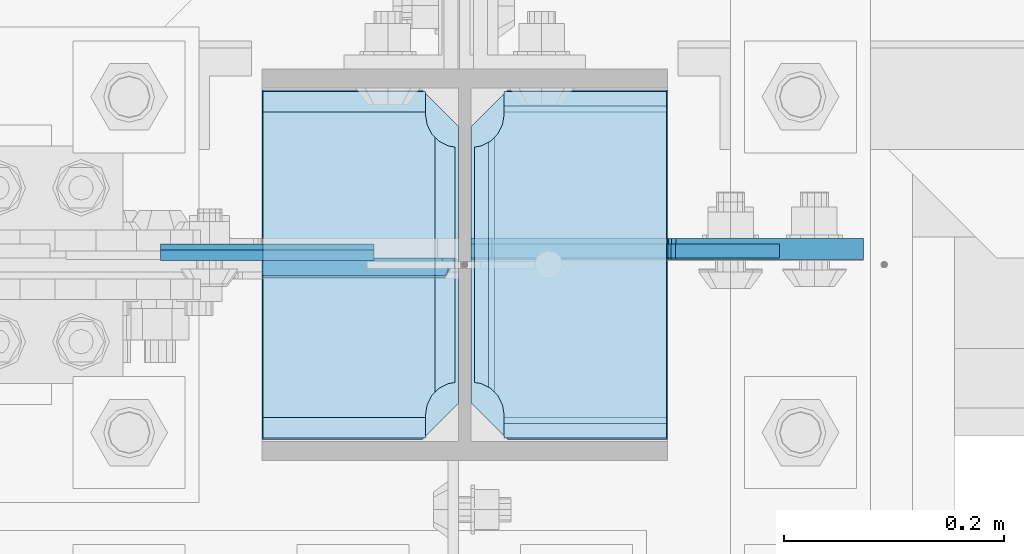
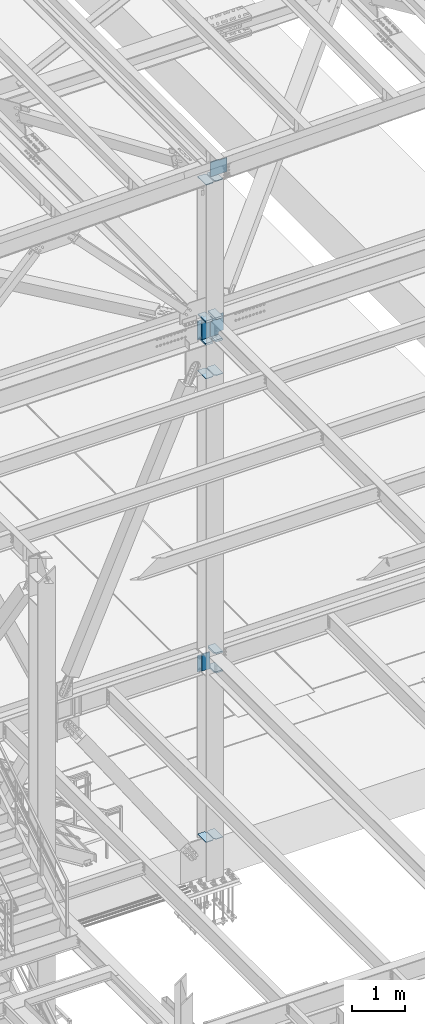
# One storey, part 3183 of 3843: 18 plates, 1 element without a shape of its own.
"""IFC2X3 building model written with IfcOpenShell, lengths in millimetres."""

from ifc_helpers import new_model, si_unit, frame, origin_with_axes, place, context, subcontext, project, spatial, faceted_brep, material, type_object, element, aggregate, save


model = new_model("IFC2X3")

# Units and contexts
model_context = context("Model", 3, precision=1e-05, world=origin_with_axes())
body_context = subcontext(model_context, "Body", "Model", "MODEL_VIEW")
ifc_project = project(units=[si_unit("LENGTHUNIT", "METRE", prefix="MILLI"), si_unit("AREAUNIT", "SQUARE_METRE"), si_unit("VOLUMEUNIT", "CUBIC_METRE"), si_unit("MASSUNIT", "GRAM", prefix="KILO"), si_unit("TIMEUNIT", "SECOND"), si_unit("PLANEANGLEUNIT", "RADIAN"), si_unit("SOLIDANGLEUNIT", "STERADIAN"), si_unit("THERMODYNAMICTEMPERATUREUNIT", "DEGREE_CELSIUS"), si_unit("LUMINOUSINTENSITYUNIT", "LUMEN")], contexts=[model_context])

# Site, building, storey
site_placement = place(None, origin_with_axes())
site = spatial("IfcSite", under=ifc_project, at=site_placement, CompositionType="ELEMENT")
building_placement = place(site_placement, origin_with_axes())
building = spatial("IfcBuilding", under=site, at=building_placement, Name="Undefined", CompositionType="ELEMENT")
storey_placement = place(building_placement, origin_with_axes())
storey = spatial("IfcBuildingStorey", under=building, at=storey_placement, Name="Undefined", CompositionType="ELEMENT", Elevation=0.0)

# Assembly, plates
assembly_placement = place(storey_placement, origin_with_axes())
assembly = element("IfcElementAssembly", 1, at=assembly_placement, inside=storey, Name="COLUMN", AssemblyPlace="NOTDEFINED", PredefinedType="RIGID_FRAME")
ifc_material = material(Name="STEEL/A572-50")
plate_type_1 = type_object("IfcPlateType", PredefinedType="NOTDEFINED")
plate_1_placement = place(assembly_placement, frame((62630.84375, 25457.15, 41164.1593790225), z_axis=(-1.0, 0.0, 0.0), x_axis=(0.0, 1.0, 0.0)))
plate_1 = element("IfcPlate", 2, at=plate_1_placement, type_object=plate_type_1, material=ifc_material, Name="CB_COL", context=body_context, shape_type="Brep", body=[
    faceted_brep([(0.0, -6.34999999999854, 33.3375015258789), (0.0, -6.34999999999854, 178.59375), (0.0, 6.34999999999854, 178.59375), (0.0, 6.34999999999854, 33.3375015258789), (317.499999999985, -6.34999999999854, 178.59375), (317.499999999985, 6.34999999999854, 178.59375), (317.499999999985, -6.34999999999854, 33.3375015258789), (317.499999999985, 6.34999999999854, 33.3375015258789), (284.162498474107, -6.34999999999854, 0.0), (284.162498474107, 6.34999999999854, 0.0), (33.3375015258789, -6.34999999999854, 0.0), (33.3375015258789, 6.34999999999854, 0.0)], [[[0, 1, 2, 3]], [[1, 4, 5, 2]], [[4, 6, 7, 5]], [[6, 8, 9, 7]], [[8, 10, 11, 9]], [[10, 0, 3, 11]], [[5, 7, 9, 11, 3, 2]], [[10, 8, 6, 4, 1, 0]]]),
])
plate_2_placement = place(assembly_placement, frame((62641.95625, 25457.15, 41164.1593790225), z_axis=(1.0, 0.0, 0.0), x_axis=(0.0, 1.0, 0.0)))
plate_2 = element("IfcPlate", 3, at=plate_2_placement, type_object=plate_type_1, material=ifc_material, Name="CB_COL", context=body_context, shape_type="Brep", body=[
    faceted_brep([(0.0, -6.34999999999854, 33.3375015258789), (0.0, -6.34999999999854, 178.59375), (0.0, 6.34999999999854, 178.59375), (0.0, 6.34999999999854, 33.3375015258789), (317.499999999985, -6.34999999999854, 178.59375), (317.499999999985, 6.34999999999854, 178.59375), (317.499999999985, -6.34999999999854, 33.3375015258789), (317.499999999985, 6.34999999999854, 33.3375015258789), (284.162498474107, -6.34999999999854, 0.0), (284.162498474107, 6.34999999999854, 0.0), (33.3375015258789, -6.34999999999854, 0.0), (33.3375015258789, 6.34999999999854, 0.0)], [[[0, 1, 2, 3]], [[1, 4, 5, 2]], [[4, 6, 7, 5]], [[6, 8, 9, 7]], [[8, 10, 11, 9]], [[10, 0, 3, 11]], [[5, 7, 9, 11, 3, 2]], [[10, 8, 6, 4, 1, 0]]]),
])
plate_3_placement = place(assembly_placement, frame((62641.95625, 25457.15, 30568.9380949005), z_axis=(1.0, 0.0, 0.0), x_axis=(0.0, 1.0, 0.0)))
plate_3 = element("IfcPlate", 4, at=plate_3_placement, type_object=plate_type_1, material=ifc_material, Name="CB_COL", context=body_context, shape_type="Brep", body=[
    faceted_brep([(0.0, -6.34999999999854, 33.3375015258789), (0.0, -6.34999999999854, 178.59375), (0.0, 6.34999999999854, 178.59375), (0.0, 6.34999999999854, 33.3375015258789), (317.499999999985, -6.34999999999854, 178.59375), (317.499999999985, 6.34999999999854, 178.59375), (317.499999999985, -6.34999999999854, 33.3375015258789), (317.499999999985, 6.34999999999854, 33.3375015258789), (284.162498474107, -6.34999999999854, 0.0), (284.162498474107, 6.34999999999854, 0.0), (33.3375015258789, -6.34999999999854, 0.0), (33.3375015258789, 6.34999999999854, 0.0)], [[[0, 1, 2, 3]], [[1, 4, 5, 2]], [[4, 6, 7, 5]], [[6, 8, 9, 7]], [[8, 10, 11, 9]], [[10, 0, 3, 11]], [[5, 7, 9, 11, 3, 2]], [[10, 8, 6, 4, 1, 0]]]),
])
plate_4_placement = place(assembly_placement, frame((62630.84375, 25457.15, 30568.9380949005), z_axis=(-1.0, 0.0, 0.0), x_axis=(0.0, 1.0, 0.0)))
plate_4 = element("IfcPlate", 5, at=plate_4_placement, type_object=plate_type_1, material=ifc_material, Name="CB_COL", context=body_context, shape_type="Brep", body=[
    faceted_brep([(0.0, -6.34999999999854, 33.3375015258789), (0.0, -6.34999999999854, 178.59375), (0.0, 6.34999999999854, 178.59375), (0.0, 6.34999999999854, 33.3375015258789), (317.499999999985, -6.34999999999854, 178.59375), (317.499999999985, 6.34999999999854, 178.59375), (317.499999999985, -6.34999999999854, 33.3375015258789), (317.499999999985, 6.34999999999854, 33.3375015258789), (284.162498474107, -6.34999999999854, 0.0), (284.162498474107, 6.34999999999854, 0.0), (33.3375015258789, -6.34999999999854, 0.0), (33.3375015258789, 6.34999999999854, 0.0)], [[[0, 1, 2, 3]], [[1, 4, 5, 2]], [[4, 6, 7, 5]], [[6, 8, 9, 7]], [[8, 10, 11, 9]], [[10, 0, 3, 11]], [[5, 7, 9, 11, 3, 2]], [[10, 8, 6, 4, 1, 0]]]),
])
plate_type_2 = type_object("IfcPlateType", PredefinedType="NOTDEFINED")
plate_5_placement = place(assembly_placement, frame((62641.95625, 25776.2375, 41941.75), z_axis=(0.0, -1.0, 0.0), x_axis=(1.0, 0.0, 0.0)))
plate_5 = element("IfcPlate", 6, at=plate_5_placement, type_object=plate_type_2, material=ifc_material, Name="PLATE", context=body_context, shape_type="Brep", body=[
    faceted_brep([(17.7290728964945, 9.33242473992141, 272.460514298873), (21.5063709990791, 15.875, 276.23781240145), (21.5063709990791, 15.875, 44.4371753915184), (17.7290728964945, 9.33242473992868, 48.2144734940957), (9.32072521071677, -5.2314900089259, 52.4987406282016), (3.17549995231093, -15.875, 53.4720486914302), (3.17549995231093, -15.875, 267.202939101539), (9.32072521071677, -5.2314900089259, 268.176247164767), (30.1625003814697, 15.875, 299.169629000906), (30.1625003814697, -15.875, 317.500500047678), (177.799999999996, -15.875, 317.500500047678), (177.799999999996, 15.875, 299.169629000906), (177.799999999996, 15.875, 21.5063709990791), (177.799999999996, -15.875, 3.17549995230729), (30.1625003814697, -15.875, 3.17549995230729), (30.1625003814697, 15.875, 21.5063709990791), (9.32072521071314, -15.875, 268.176259371801), (17.7290728964945, -15.875, 272.460526505907), (24.401975401448, -15.875, 279.133429010864), (24.401975401448, 15.875, 279.133429010864), (28.6862425355503, -15.875, 287.541776696642), (28.6862425355503, 15.875, 287.541776696642), (30.1625003814697, -15.875, 296.862501907352), (30.1625003814697, 15.875, 296.862501907352), (30.1625003814697, -15.875, 23.8124980926514), (30.1625003814697, 15.875, 23.8124980926514), (28.6862425355503, -15.875, 33.1332233033609), (28.6862425355503, 15.875, 33.1332233033609), (24.401975401448, -15.875, 41.5415709891386), (24.401975401448, 15.875, 41.5415709891386), (17.7290728964945, -15.875, 48.2144734940957), (9.32072521071677, -15.875, 52.4987406282016)], [[[0, 1, 2, 3, 4, 5, 6, 7]], [[8, 9, 10, 11]], [[12, 13, 14, 15]], [[16, 7, 6]], [[16, 17, 0, 7]], [[17, 18, 19, 1, 0]], [[18, 20, 21, 19]], [[20, 22, 23, 21]], [[23, 22, 9, 8]], [[11, 10, 13, 12]], [[24, 25, 15, 14]], [[24, 26, 27, 25]], [[26, 28, 29, 27]], [[29, 28, 30, 3, 2]], [[30, 31, 4, 3]], [[31, 5, 4]], [[19, 21, 23, 8, 11, 12, 15, 25, 27, 29, 2, 1]], [[31, 30, 28, 26, 24, 14, 13, 10, 9, 22, 20, 18, 17, 16, 6, 5]]]),
])
plate_6_placement = place(assembly_placement, frame((62641.95625, 25776.2375, 42452.925), z_axis=(0.0, -1.0, 0.0), x_axis=(1.0, 0.0, 0.0)))
plate_6 = element("IfcPlate", 7, at=plate_6_placement, type_object=plate_type_2, material=ifc_material, Name="PLATE", context=body_context, shape_type="Brep", body=[
    faceted_brep([(17.7290728964945, 9.33263080204051, 272.460514298873), (21.5063709990791, 15.875, 276.23781240145), (21.5063709990791, 15.875, 44.4371753915184), (17.7290728964945, 9.33263080204051, 48.2144734940957), (9.32072521071677, -5.23082524805068, 52.4987406282016), (3.17549995231093, -15.875, 53.4720486914302), (3.17549995231093, -15.875, 267.202939101539), (9.32072521071677, -5.23082524805068, 268.176247164767), (30.1625003814697, 15.875, 299.169629000906), (30.1625003814697, -15.875, 317.500500047678), (177.799999999996, -15.875, 317.500500047678), (177.799999999996, 15.875, 299.169629000906), (177.799999999996, 15.875, 21.5063709990791), (177.799999999996, -15.875, 3.17549995230729), (30.1625003814697, -15.875, 3.17549995230729), (30.1625003814697, 15.875, 21.5063709990791), (9.32072521071314, -15.875, 268.176259371801), (17.7290728964945, -15.875, 272.460526505907), (24.401975401448, -15.875, 279.133429010864), (24.401975401448, 15.875, 279.133429010864), (28.6862425355503, -15.875, 287.541776696642), (28.6862425355503, 15.875, 287.541776696642), (30.1625003814697, -15.875, 296.862501907352), (30.1625003814697, 15.875, 296.862501907352), (30.1625003814697, -15.875, 23.8124980926514), (30.1625003814697, 15.875, 23.8124980926514), (28.6862425355503, -15.875, 33.1332233033609), (28.6862425355503, 15.875, 33.1332233033609), (24.401975401448, -15.875, 41.5415709891386), (24.401975401448, 15.875, 41.5415709891386), (17.7290728964945, -15.875, 48.2144734940957), (9.32072521071677, -15.875, 52.4987406282016)], [[[0, 1, 2, 3, 4, 5, 6, 7]], [[8, 9, 10, 11]], [[12, 13, 14, 15]], [[16, 7, 6]], [[16, 17, 0, 7]], [[17, 18, 19, 1, 0]], [[18, 20, 21, 19]], [[20, 22, 23, 21]], [[23, 22, 9, 8]], [[11, 10, 13, 12]], [[24, 25, 15, 14]], [[24, 26, 27, 25]], [[26, 28, 29, 27]], [[29, 28, 30, 3, 2]], [[30, 31, 4, 3]], [[31, 5, 4]], [[19, 21, 23, 8, 11, 12, 15, 25, 27, 29, 2, 1]], [[31, 30, 28, 26, 24, 14, 13, 10, 9, 22, 20, 18, 17, 16, 6, 5]]]),
])
plate_7_placement = place(assembly_placement, frame((62453.04375, 25776.2375, 41941.75), z_axis=(0.0, -1.0, 0.0), x_axis=(1.0, 0.0, 0.0)))
plate_7 = element("IfcPlate", 8, at=plate_7_placement, type_object=plate_type_2, material=ifc_material, Name="PLATE", context=body_context, shape_type="Brep", body=[
    faceted_brep([(160.070927103505, 9.33329077896633, 48.2144734940957), (156.294129000915, 15.875, 44.437675391513), (156.294129000915, 15.875, 276.23732460849), (160.070927103505, 9.33329077896633, 272.460526505907), (168.479274789282, -5.23062396988826, 268.176259371801), (174.625000047687, -15.875, 267.202872116366), (174.625000047687, -15.875, 53.4721278836369), (168.479274789282, -5.23062396988826, 52.4987406282016), (147.637499618526, 15.875, 21.5063709990791), (147.637499618526, -15.875, 3.17549995230729), (0.0, -15.875, 3.17549995230729), (0.0, 15.875, 21.5063709990791), (0.0, 15.875, 299.169629000906), (0.0, -15.875, 317.500500047678), (147.637499618526, -15.875, 317.500500047678), (147.637499618526, 15.875, 299.169629000906), (147.63749961853, -15.875, 296.862501907352), (147.63749961853, 15.875, 296.862501907352), (149.113757464445, -15.875, 287.541776696642), (149.113757464445, 15.875, 287.541776696642), (153.398024598548, -15.875, 279.133429010864), (153.398024598548, 15.875, 279.133429010864), (160.070927103505, -15.875, 272.460526505907), (168.479274789282, -15.875, 268.176259371801), (168.479274789282, -15.875, 52.4987406282016), (160.070927103505, -15.875, 48.2144734940957), (153.398024598548, -15.875, 41.5415709891386), (153.398024598548, 15.875, 41.5415709891386), (149.113757464449, -15.875, 33.1332233033609), (149.113757464449, 15.875, 33.1332233033609), (147.63749961853, -15.875, 23.8124980926514), (147.63749961853, 15.875, 23.8124980926514)], [[[0, 1, 2, 3, 4, 5, 6, 7]], [[8, 9, 10, 11]], [[12, 13, 14, 15]], [[13, 12, 11, 10]], [[16, 17, 15, 14]], [[16, 18, 19, 17]], [[18, 20, 21, 19]], [[21, 20, 22, 3, 2]], [[22, 23, 4, 3]], [[23, 5, 4]], [[24, 7, 6]], [[24, 25, 0, 7]], [[25, 26, 27, 1, 0]], [[26, 28, 29, 27]], [[28, 30, 31, 29]], [[31, 30, 9, 8]], [[27, 29, 31, 8, 11, 12, 15, 17, 19, 21, 2, 1]], [[9, 30, 28, 26, 25, 24, 6, 5, 23, 22, 20, 18, 16, 14, 13, 10]]]),
])
plate_8_placement = place(assembly_placement, frame((62453.04375, 25776.2375, 42452.925), z_axis=(0.0, -1.0, 0.0), x_axis=(1.0, 0.0, 0.0)))
plate_8 = element("IfcPlate", 9, at=plate_8_placement, type_object=plate_type_2, material=ifc_material, Name="PLATE", context=body_context, shape_type="Brep", body=[
    faceted_brep([(160.070927103505, 9.33349681380787, 48.2144734940957), (156.294129000915, 15.875, 44.437675391513), (156.294129000915, 15.875, 276.23732460849), (160.070927103505, 9.33349681380787, 272.460526505907), (168.479274789282, -5.2299592362906, 268.176259371801), (174.625000047687, -15.875, 267.202872116366), (174.625000047687, -15.875, 53.4721278836369), (168.479274789282, -5.2299592362906, 52.4987406282016), (147.637499618526, 15.875, 21.5063709990791), (147.637499618526, -15.875, 3.17549995230729), (0.0, -15.875, 3.17549995230729), (0.0, 15.875, 21.5063709990791), (0.0, 15.875, 299.169629000906), (0.0, -15.875, 317.500500047678), (147.637499618526, -15.875, 317.500500047678), (147.637499618526, 15.875, 299.169629000906), (147.63749961853, -15.875, 296.862501907352), (147.63749961853, 15.875, 296.862501907352), (149.113757464445, -15.875, 287.541776696642), (149.113757464445, 15.875, 287.541776696642), (153.398024598548, -15.875, 279.133429010864), (153.398024598548, 15.875, 279.133429010864), (160.070927103505, -15.875, 272.460526505907), (168.479274789282, -15.875, 268.176259371801), (168.479274789282, -15.875, 52.4987406282016), (160.070927103505, -15.875, 48.2144734940957), (153.398024598548, -15.875, 41.5415709891386), (153.398024598548, 15.875, 41.5415709891386), (149.113757464449, -15.875, 33.1332233033609), (149.113757464449, 15.875, 33.1332233033609), (147.63749961853, -15.875, 23.8124980926514), (147.63749961853, 15.875, 23.8124980926514)], [[[0, 1, 2, 3, 4, 5, 6, 7]], [[8, 9, 10, 11]], [[12, 13, 14, 15]], [[13, 12, 11, 10]], [[16, 17, 15, 14]], [[16, 18, 19, 17]], [[18, 20, 21, 19]], [[21, 20, 22, 3, 2]], [[22, 23, 4, 3]], [[23, 5, 4]], [[24, 7, 6]], [[24, 25, 0, 7]], [[25, 26, 27, 1, 0]], [[26, 28, 29, 27]], [[28, 30, 31, 29]], [[31, 30, 9, 8]], [[27, 29, 31, 8, 11, 12, 15, 17, 19, 21, 2, 1]], [[9, 30, 28, 26, 25, 24, 6, 5, 23, 22, 20, 18, 16, 14, 13, 10]]]),
])
plate_type_3 = type_object("IfcPlateType", PredefinedType="NOTDEFINED")
plate_9_placement = place(assembly_placement, frame((62360.175, 25624.63125, 34771.0125), z_axis=(0.0, 0.0, -1.0), x_axis=(1.0, 0.0, 0.0)))
plate_9 = element("IfcPlate", 10, at=plate_9_placement, type_object=plate_type_3, material=ifc_material, Name="PLATE", context=body_context, shape_type="Brep", body=[
    faceted_brep([(0.0, -4.76249999999709, 0.0), (8.90977389644831e-08, -4.76249999999709, 371.474998644393), (8.90977389644831e-08, 4.76249999999709, 371.474998644393), (0.0, 4.76249999999709, 0.0), (193.675000089086, -4.76249999999709, 371.474998644226), (193.675000089086, 4.76249999999709, 371.474998644226), (193.674999999996, -4.76249999999709, 0.0), (193.674999999996, 4.76249999999709, 0.0)], [[[0, 1, 2, 3]], [[1, 4, 5, 2]], [[4, 6, 7, 5]], [[6, 0, 3, 7]], [[5, 7, 3, 2]], [[6, 4, 1, 0]]]),
])
plate_type_4 = type_object("IfcPlateType", PredefinedType="NOTDEFINED")
plate_10_placement = place(assembly_placement, frame((62630.84375, 25611.93125, 34401.1250026494), z_axis=(-0.707106781186548, 0.0, 0.707106781186548), x_axis=(-0.707106781186548, 0.0, -0.707106781186548)))
plate_10 = element("IfcPlate", 11, at=plate_10_placement, type_object=plate_type_4, material=ifc_material, Name="PLATE", context=body_context, shape_type="Brep", body=[
    faceted_brep([(-256.445797883454, 7.93749999884676, 273.897809073245), (13.470384184775, 7.9375, 3.98162703046546), (13.4703841731916, 3.06102272879798, -7.27595761418343e-12), (4.49012799309094, -7.9375, 7.27595761418343e-12), (-260.427429442891, -7.9375, 264.917557448716), (-260.427429442905, 3.06101715000841, 273.89780903011), (-260.427429442934, -7.9375, 282.878060804574), (-145.367895964562, -7.9375, 397.937599356294), (-138.886955365218, 7.9374999648353, 391.456654945894), (22.4506403026729, -7.93750001103617, 0.0), (131.029230272985, 7.9375, 121.540473118737), (137.510171884061, -7.9375, 115.059531507664), (112.81446822444, 7.9375, 139.755234990844), (112.81446822444, -7.9375, 139.755234990844), (-120.672192386237, 7.9375, 373.241892121674), (-120.672192386237, -7.9375, 373.241892121674)], [[[0, 1, 2, 3, 4, 5]], [[6, 7, 8, 0, 5]], [[9, 3, 2]], [[10, 11, 9, 2, 1]], [[12, 13, 11, 10]], [[14, 15, 13, 12]], [[15, 14, 8, 7]], [[4, 3, 9, 11, 13, 15, 7, 6]], [[6, 5, 4]], [[8, 14, 12, 10, 1, 0]]]),
])
plate_type_5 = type_object("IfcPlateType", PredefinedType="NOTDEFINED")
plate_11_placement = place(assembly_placement, frame((62360.175, 25628.6, 42413.2375), z_axis=(0.0, 0.0, -1.0), x_axis=(1.0, 0.0, 0.0)))
plate_11 = element("IfcPlate", 12, at=plate_11_placement, type_object=plate_type_5, material=ifc_material, Name="PLATE", context=body_context, shape_type="Brep", body=[
    faceted_brep([(0.0, -6.3499999046162, 0.0), (0.0, -6.35000000000582, 431.800000000003), (0.0, 6.35000000000582, 431.800000000003), (7.27595761418343e-12, 6.3499999046162, 0.0), (193.674999999996, -6.35000000000582, 431.800000000003), (193.674999999996, 6.35000000000582, 431.800000000003), (193.674999999996, -6.35000000000582, 0.0), (193.674999999996, 6.35000000000582, 0.0)], [[[0, 1, 2, 3]], [[1, 4, 5, 2]], [[4, 6, 7, 5]], [[6, 0, 3, 7]], [[5, 7, 3, 2]], [[6, 4, 1, 0]]]),
])
plate_type_6 = type_object("IfcPlateType", PredefinedType="NOTDEFINED")
plate_12_placement = place(assembly_placement, frame((62630.8437499996, 25614.3125, 41976.675), z_axis=(-0.707106781186548, 0.0, 0.707106781186548), x_axis=(-0.707106781186548, 0.0, -0.707106781186548)))
plate_12 = element("IfcPlate", 13, at=plate_12_placement, type_object=plate_type_6, material=ifc_material, Name="PLATE", context=body_context, shape_type="Brep", body=[
    faceted_brep([(-308.082449934242, 7.9375, 325.534107581119), (13.4702073986555, 7.9375, 3.98145024821861), (13.4702065513266, 3.06123817239859, 1.2732925824821e-11), (4.48977442465548, -7.9375, 0.0), (-312.06390018767, -7.9375, 316.553674612336), (-312.06390018767, 3.06123817684784, 325.534106742647), (131.029230272985, 7.9375, 121.540473118737), (137.510171884061, -7.9375, 115.059531507664), (22.4506403026729, -7.93750001103617, 0.0), (-312.06390018767, -7.9375, 334.514540549832), (-197.004368672904, -7.9375, 449.574072064608), (-190.523427061838, 7.9375, 443.093130453524), (-177.921324252063, -7.9375, 430.491027643751), (-177.921324252063, 7.9375, 430.491027643751), (118.427127456042, -7.9375, 134.142575935628), (118.427127456042, 7.9375, 134.142575935628)], [[[0, 1, 2, 3, 4, 5]], [[6, 7, 8, 2, 1]], [[9, 5, 4]], [[9, 10, 11, 0, 5]], [[12, 13, 11, 10]], [[13, 12, 14, 15]], [[15, 14, 7, 6]], [[11, 13, 15, 6, 1, 0]], [[8, 3, 2]], [[14, 12, 10, 9, 4, 3, 8, 7]]]),
])
plate_type_7 = type_object("IfcPlateType", PredefinedType="NOTDEFINED")
plate_13_placement = place(assembly_placement, frame((62641.95625, 25776.2375, 34370.9625), z_axis=(0.0, -1.0, 0.0), x_axis=(1.0, 0.0, 0.0)))
plate_13 = element("IfcPlate", 14, at=plate_13_placement, type_object=plate_type_7, material=ifc_material, Name="PLATE", context=body_context, shape_type="Brep", body=[
    faceted_brep([(16.0071099052948, 11.1125000000029, 271.583142538795), (16.0071099052948, 11.1125000000029, 49.0918574612078), (9.32072521071677, -0.468658009958745, 52.4987406282016), (3.17549995231093, -11.1125000000029, 53.472048691423), (3.17549995231093, -11.1125000000029, 267.202951308576), (9.32072521071677, -0.468658009958745, 268.176259371798), (30.1625003814697, 11.1125000000029, 304.668890094701), (30.1625003814697, -11.1125000000029, 317.500500047681), (177.799999999996, -11.1125000000029, 317.500500047681), (177.799999999996, 11.1125000000029, 304.668890094701), (177.799999999996, 11.1125000000029, 16.0071099052911), (177.799999999996, -11.1125000000029, 3.17549995231093), (30.1625003814697, -11.1125000000029, 3.17549995231093), (30.1625003814697, 11.1125000000029, 16.0071099052911), (9.32072521071677, -11.1125000000029, 268.176259371798), (17.7290728964945, -11.1125000000029, 272.4605265059), (17.7290728964945, 11.1125000000029, 272.4605265059), (24.4019754014516, -11.1125000000029, 279.133429010853), (24.4019754014516, 11.1125000000029, 279.133429010853), (28.6862425355503, -11.1125000000029, 287.541776696635), (28.6862425355503, 11.1125000000029, 287.541776696635), (30.1625003814697, -11.1125000000029, 296.862501907348), (30.1625003814697, 11.1125000000029, 296.862501907348), (30.1625003814697, -11.1125000000029, 23.8124980926514), (30.1625003814697, 11.1125000000029, 23.8124980926514), (28.6862425355503, -11.1125000000029, 33.1332233033681), (28.6862425355503, 11.1125000000029, 33.1332233033681), (24.4019754014516, -11.1125000000029, 41.5415709891458), (24.4019754014516, 11.1125000000029, 41.5415709891458), (17.7290728964945, -11.1125000000029, 48.214473494103), (17.7290728964945, 11.1125000000029, 48.214473494103), (9.32072521071677, -11.1125000000029, 52.4987406282016)], [[[0, 1, 2, 3, 4, 5]], [[6, 7, 8, 9]], [[10, 11, 12, 13]], [[14, 5, 4]], [[14, 15, 16, 0, 5]], [[15, 17, 18, 16]], [[17, 19, 20, 18]], [[19, 21, 22, 20]], [[22, 21, 7, 6]], [[11, 10, 9, 8]], [[23, 24, 13, 12]], [[23, 25, 26, 24]], [[25, 27, 28, 26]], [[27, 29, 30, 28]], [[30, 29, 31, 2, 1]], [[31, 3, 2]], [[16, 18, 20, 22, 6, 9, 10, 13, 24, 26, 28, 30, 1, 0]], [[31, 29, 27, 25, 23, 12, 11, 8, 7, 21, 19, 17, 15, 14, 4, 3]]]),
])
plate_14_placement = place(assembly_placement, frame((62641.95625, 25776.2375, 34799.5875), z_axis=(0.0, -1.0, 0.0), x_axis=(1.0, 0.0, 0.0)))
plate_14 = element("IfcPlate", 15, at=plate_14_placement, type_object=plate_type_7, material=ifc_material, Name="PLATE", context=body_context, shape_type="Brep", body=[
    faceted_brep([(16.0071099052948, 11.1125000000029, 271.583142538795), (16.0071099052948, 11.1125000000029, 49.0918574612078), (9.32072521071677, -0.468658009958745, 52.4987406282016), (3.17549995231093, -11.1125000000029, 53.472048691423), (3.17549995231093, -11.1125000000029, 267.202951308576), (9.32072521071677, -0.468658009958745, 268.176259371798), (30.1625003814697, 11.1125000000029, 304.668890094701), (30.1625003814697, -11.1125000000029, 317.500500047681), (177.799999999996, -11.1125000000029, 317.500500047681), (177.799999999996, 11.1125000000029, 304.668890094701), (177.799999999996, 11.1125000000029, 16.0071099052911), (177.799999999996, -11.1125000000029, 3.17549995231093), (30.1625003814697, -11.1125000000029, 3.17549995231093), (30.1625003814697, 11.1125000000029, 16.0071099052911), (9.32072521071677, -11.1125000000029, 268.176259371798), (17.7290728964945, -11.1125000000029, 272.4605265059), (17.7290728964945, 11.1125000000029, 272.4605265059), (24.4019754014516, -11.1125000000029, 279.133429010853), (24.4019754014516, 11.1125000000029, 279.133429010853), (28.6862425355503, -11.1125000000029, 287.541776696635), (28.6862425355503, 11.1125000000029, 287.541776696635), (30.1625003814697, -11.1125000000029, 296.862501907348), (30.1625003814697, 11.1125000000029, 296.862501907348), (30.1625003814697, -11.1125000000029, 23.8124980926514), (30.1625003814697, 11.1125000000029, 23.8124980926514), (28.6862425355503, -11.1125000000029, 33.1332233033681), (28.6862425355503, 11.1125000000029, 33.1332233033681), (24.4019754014516, -11.1125000000029, 41.5415709891458), (24.4019754014516, 11.1125000000029, 41.5415709891458), (17.7290728964945, -11.1125000000029, 48.214473494103), (17.7290728964945, 11.1125000000029, 48.214473494103), (9.32072521071677, -11.1125000000029, 52.4987406282016)], [[[0, 1, 2, 3, 4, 5]], [[6, 7, 8, 9]], [[10, 11, 12, 13]], [[14, 5, 4]], [[14, 15, 16, 0, 5]], [[15, 17, 18, 16]], [[17, 19, 20, 18]], [[19, 21, 22, 20]], [[22, 21, 7, 6]], [[11, 10, 9, 8]], [[23, 24, 13, 12]], [[23, 25, 26, 24]], [[25, 27, 28, 26]], [[27, 29, 30, 28]], [[30, 29, 31, 2, 1]], [[31, 3, 2]], [[16, 18, 20, 22, 6, 9, 10, 13, 24, 26, 28, 30, 1, 0]], [[31, 29, 27, 25, 23, 12, 11, 8, 7, 21, 19, 17, 15, 14, 4, 3]]]),
])
plate_type_8 = type_object("IfcPlateType", PredefinedType="NOTDEFINED")
plate_15_placement = place(assembly_placement, frame((62819.75625, 25457.15, 45603.9146479399), z_axis=(0.0, 1.0, 0.0), x_axis=(-1.0, 0.0, 0.0)))
plate_15 = element("IfcPlate", 16, at=plate_15_placement, type_object=plate_type_8, material=ifc_material, Name="PLATE", context=body_context, shape_type="Brep", body=[
    faceted_brep([(0.0, -9.52500000000146, 0.0), (0.0, -9.52500000000146, 317.5), (0.0, 9.52500000000146, 317.5), (0.0, 9.52500000000146, 0.0), (144.462501525879, -9.52500000000146, 317.5), (144.462501525879, 9.52500000000146, 317.5), (177.800003051758, -9.52500000000146, 284.162498474121), (177.800003051758, 9.52500000000146, 284.162498474121), (177.800003051758, -9.52500000000146, 33.3375015258789), (177.800003051758, 9.52500000000146, 33.3375015258789), (144.462501525879, -9.52500000000146, 0.0), (144.462501525879, 9.52500000000146, 0.0)], [[[0, 1, 2, 3]], [[1, 4, 5, 2]], [[4, 6, 7, 5]], [[6, 8, 9, 7]], [[8, 10, 11, 9]], [[10, 0, 3, 11]], [[5, 7, 9, 11, 3, 2]], [[10, 8, 6, 4, 1, 0]]]),
])
plate_16_placement = place(assembly_placement, frame((62453.0437499977, 25774.6499999999, 45592.4102004843), z_axis=(0.0, -1.0, 0.0), x_axis=(1.0, 0.0, 0.0)))
plate_16 = element("IfcPlate", 17, at=plate_16_placement, type_object=plate_type_8, material=ifc_material, Name="PLATE", context=body_context, shape_type="Brep", body=[
    faceted_brep([(0.0, -9.52500000000146, 0.0), (0.0, -9.52500000000146, 317.5), (0.0, 9.52500000000146, 317.5), (0.0, 9.52500000000146, 0.0), (144.462501525879, -9.52500000000146, 317.5), (144.462501525879, 9.52500000000146, 317.5), (177.800003051758, -9.52500000000146, 284.162498474121), (177.800003051758, 9.52500000000146, 284.162498474121), (177.800003051758, -9.52500000000146, 33.3375015258789), (177.800003051758, 9.52500000000146, 33.3375015258789), (144.462501525879, -9.52500000000146, 0.0), (144.462501525879, 9.52500000000146, 0.0)], [[[0, 1, 2, 3]], [[1, 4, 5, 2]], [[4, 6, 7, 5]], [[6, 8, 9, 7]], [[8, 10, 11, 9]], [[10, 0, 3, 11]], [[5, 7, 9, 11, 3, 2]], [[10, 8, 6, 4, 1, 0]]]),
])
plate_type_9 = type_object("IfcPlateType", PredefinedType="NOTDEFINED")
plate_17_placement = place(assembly_placement, frame((62641.95625, 25628.6000000954, 41976.675), z_axis=(0.707106781186548, 0.0, 0.707106781186548), x_axis=(0.707106781186548, 0.0, -0.707106781186548)))
plate_17 = element("IfcPlate", 18, at=plate_17_placement, type_object=plate_type_9, material=ifc_material, Name="PLATE", context=body_context, shape_type="Brep", body=[
    faceted_brep([(0.0, -6.3499999046162, 0.0), (-312.063900185356, -6.35000000000582, 312.063900214343), (-312.063900185356, 6.35000000000582, 312.063900214343), (7.27595761418343e-12, 6.3499999046162, 0.0), (-312.063900205583, -6.35000000000582, 339.004668568785), (-312.063900205583, 6.35000000000582, 339.004668568785), (-199.810698692741, -6.35000000000582, 451.257870081594), (-199.810698692741, 6.35000000000582, 451.257870081594), (-190.830442436865, -6.35000000000582, 442.277613825718), (-190.830442436865, 6.35000000000582, 442.277613825718), (-186.710265968726, -6.35000000000582, 439.524599925237), (-186.710265968726, 6.35000000000582, 439.524599925237), (-181.850186450694, -6.35000000000582, 438.557870002638), (-181.850186450694, 6.35000000000582, 438.557870002638), (-176.990106932659, -6.35000000000582, 439.524599925237), (-176.990106932659, 6.35000000000582, 439.524599925237), (-172.869930464509, -6.35000000000582, 442.277613825703), (-172.869930464509, 6.35000000000582, 442.277613825703), (-109.446871474913, -6.35000000000582, 505.700672815292), (-109.446871474913, 6.35000000000582, 505.700672815292), (168.941068276839, -6.35000000000582, 227.312733063431), (168.941068276839, 6.35000000000582, 227.312733063431), (105.518009287243, -6.35000000000582, 163.889674073842), (105.518009287243, 6.35000000000582, 163.889674073842), (102.764995386762, -6.35000000000582, 159.76949760571), (102.764995386762, 6.35000000000582, 159.76949760571), (101.798265464178, -6.35000000000582, 154.909418087671), (101.798265464178, 6.35000000000582, 154.909418087671), (102.764995386762, -6.35000000000582, 150.049338569632), (102.764995386762, 6.35000000000582, 150.049338569632), (105.518009287232, -6.35000000000582, 145.929162101485), (105.518009287232, 6.35000000000582, 145.929162101485), (139.193969875923, -6.35000000000582, 112.25320151278), (139.193969875923, 6.35000000000582, 112.25320151278), (26.9407683632217, -6.34999999999854, 1.30967237055302e-10), (26.9407683632217, 6.34999999999854, 1.30967237055302e-10)], [[[0, 1, 2, 3]], [[1, 4, 5, 2]], [[4, 6, 7, 5]], [[6, 8, 9, 7]], [[8, 10, 11, 9]], [[10, 12, 13, 11]], [[12, 14, 15, 13]], [[14, 16, 17, 15]], [[16, 18, 19, 17]], [[18, 20, 21, 19]], [[20, 22, 23, 21]], [[22, 24, 25, 23]], [[24, 26, 27, 25]], [[26, 28, 29, 27]], [[28, 30, 31, 29]], [[30, 32, 33, 31]], [[32, 34, 35, 33]], [[34, 0, 3, 35]], [[5, 7, 9, 11, 13, 15, 17, 19, 21, 23, 25, 27, 29, 31, 33, 35, 3, 2]], [[34, 32, 30, 28, 26, 24, 22, 20, 18, 16, 14, 12, 10, 8, 6, 4, 1, 0]]]),
])
plate_type_10 = type_object("IfcPlateType", PredefinedType="NOTDEFINED")
plate_18_placement = place(assembly_placement, frame((62641.95625, 25630.1875003815, 45632.4896479133), z_axis=(0.707106781186548, 0.0, 0.707106781186548), x_axis=(0.707106781186548, 0.0, -0.707106781186548)))
plate_18 = element("IfcPlate", 19, at=plate_18_placement, type_object=plate_type_10, material=ifc_material, Name="PLATE", context=body_context, shape_type="Brep", body=[
    faceted_brep([(0.0, -9.52500000000146, 0.0), (-209.979301496754, -9.52500000000146, 209.979301496671), (-209.979301496754, 9.52500000000146, 209.979301496671), (0.0, 9.52500000000146, 0.0), (-209.979301496471, -9.52500000000146, 236.920069860033), (-209.979301496471, 9.52500000000146, 236.920069860033), (-97.1648339737767, -9.52500000000146, 349.734537382756), (-97.1648339737767, 9.52500000000146, 349.734537382756), (-93.3396839560301, -9.52500000000146, 345.909387365013), (-93.3396839560301, 9.52500000000146, 345.909387365013), (-89.219507487891, -9.52500000000146, 343.156373464546), (-89.219507487891, 9.52500000000146, 343.156373464546), (-84.35942796983, -9.52500000000146, 342.189643541991), (-84.35942796983, 9.52500000000146, 342.189643541991), (-79.4993484517727, -9.52500000000146, 343.15637346459), (-79.4993484517727, 9.52500000000146, 343.15637346459), (-75.3791719835863, -9.52500000000146, 345.909387365115), (-75.3791719835863, 9.52500000000146, 345.909387365115), (41.3641577270682, -9.52500000000146, 462.652717075805), (41.3641577270682, 9.52500000000146, 462.652717075805), (265.870560752759, -9.52500000000146, 238.146314050202), (265.870560752759, 9.52500000000146, 238.146314050202), (26.9407683632344, -9.52499999999964, 2.03726813197136e-10), (26.9407683632344, 9.52499999999964, 2.03726813197136e-10)], [[[0, 1, 2, 3]], [[1, 4, 5, 2]], [[4, 6, 7, 5]], [[6, 8, 9, 7]], [[8, 10, 11, 9]], [[10, 12, 13, 11]], [[12, 14, 15, 13]], [[14, 16, 17, 15]], [[16, 18, 19, 17]], [[18, 20, 21, 19]], [[20, 22, 23, 21]], [[22, 0, 3, 23]], [[5, 7, 9, 11, 13, 15, 17, 19, 21, 23, 3, 2]], [[22, 20, 18, 16, 14, 12, 10, 8, 6, 4, 1, 0]]]),
])
aggregate(assembly, [plate_9, plate_10, plate_11, plate_12, plate_5, plate_6, plate_13, plate_14, plate_1, plate_2, plate_17, plate_3, plate_4, plate_7, plate_8, plate_15, plate_18, plate_16])

save(model, "model.ifc")
